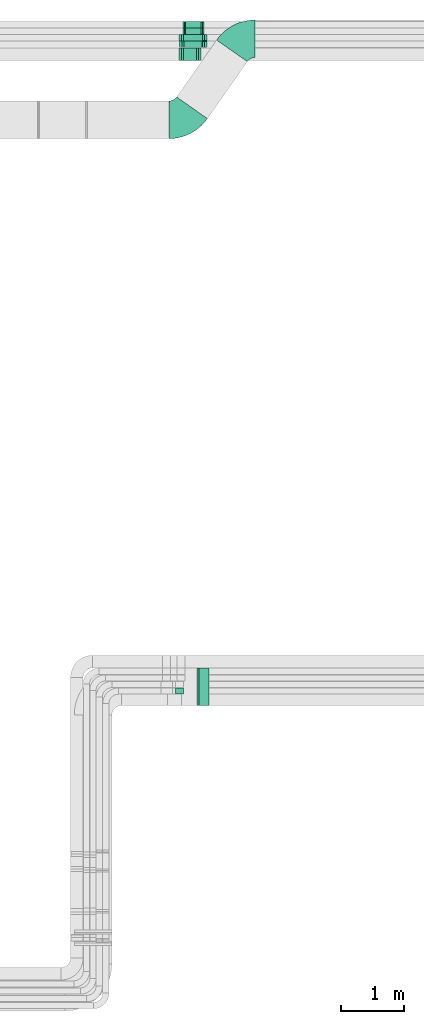
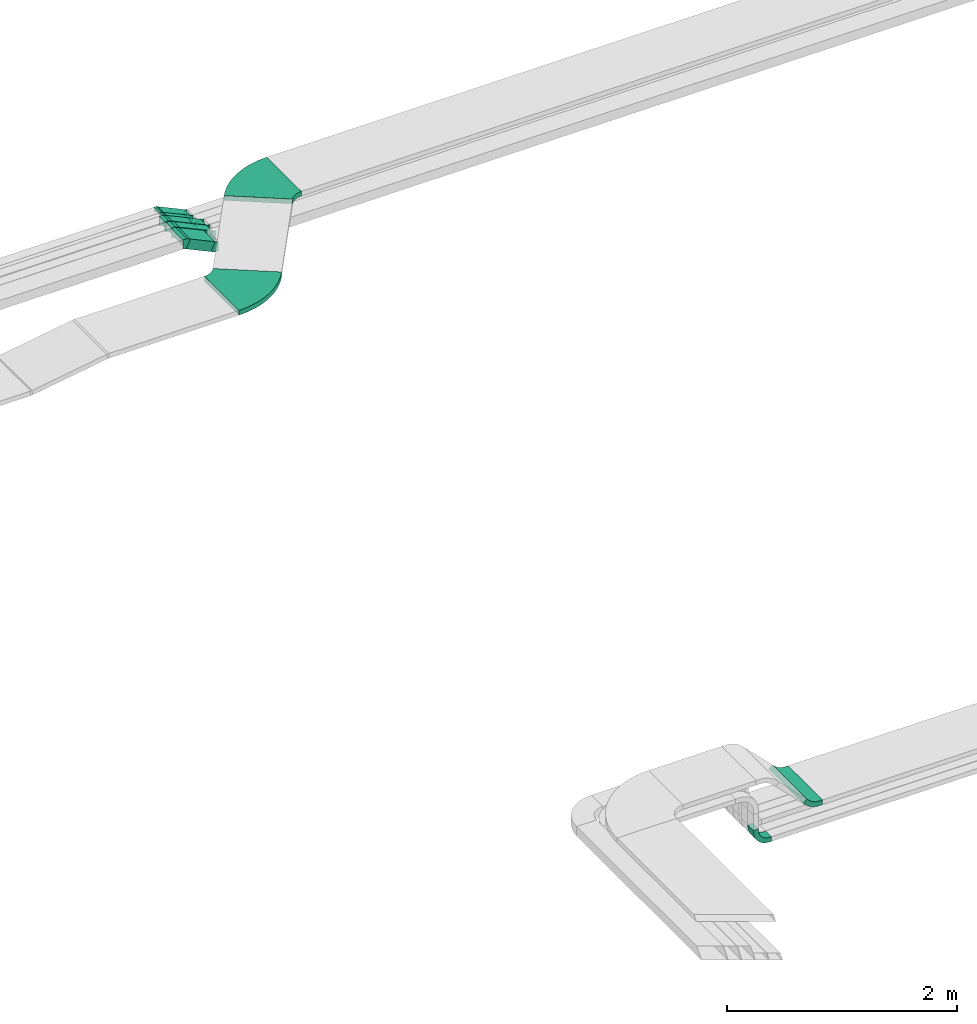
# One storey, part 29 of 38: 14 flow fittings, 5 flow segments.
"""IFC2X3 building model written with IfcOpenShell, lengths in millimetres."""

from ifc_helpers import new_model, entity, si_unit, converted_unit, derived_unit, direction, frame, frame_2d, origin, origin_2d_with_axis, place, context, subcontext, project, spatial, polyline, circle_curve, parameter, trimmed, segment, composite_curve, rectangle, outline, extrude, faceted_brep, source, transform, mapped, material, type_object, type_shapes, element, save


model = new_model("IFC2X3")

# Units and contexts
model_context = context("Model", 3, precision=0.01, world=origin(), true_north=direction((6.12303176911189e-17, 1.0)))
body_context = subcontext(model_context, "Body", "Model", "MODEL_VIEW")
ifc_project = project(units=[si_unit("LENGTHUNIT", "METRE", prefix="MILLI"), si_unit("AREAUNIT", "SQUARE_METRE"), si_unit("VOLUMEUNIT", "CUBIC_METRE"), converted_unit("PLANEANGLEUNIT", "DEGREE", entity("IfcRatioMeasure", 0.0174532925199433), si_unit("PLANEANGLEUNIT", "RADIAN"), dimensions=[0, 0, 0, 0, 0, 0, 0]), si_unit("MASSUNIT", "GRAM", prefix="KILO"), derived_unit("MASSDENSITYUNIT", [(si_unit("MASSUNIT", "GRAM", prefix="KILO"), 1), (si_unit("LENGTHUNIT", "METRE"), -3)]), derived_unit("MOMENTOFINERTIAUNIT", [(si_unit("LENGTHUNIT", "METRE"), 4)]), si_unit("TIMEUNIT", "SECOND"), si_unit("FREQUENCYUNIT", "HERTZ"), si_unit("THERMODYNAMICTEMPERATUREUNIT", "DEGREE_CELSIUS"), derived_unit("THERMALTRANSMITTANCEUNIT", [(si_unit("MASSUNIT", "GRAM", prefix="KILO"), 1), (si_unit("THERMODYNAMICTEMPERATUREUNIT", "KELVIN"), -1), (si_unit("TIMEUNIT", "SECOND"), -3)]), derived_unit("VOLUMETRICFLOWRATEUNIT", [(si_unit("LENGTHUNIT", "METRE"), 3), (si_unit("TIMEUNIT", "SECOND"), -1)]), derived_unit("MASSFLOWRATEUNIT", [(si_unit("MASSUNIT", "GRAM", prefix="KILO"), 1), (si_unit("TIMEUNIT", "SECOND"), -1)]), derived_unit("ROTATIONALFREQUENCYUNIT", [(si_unit("TIMEUNIT", "SECOND"), -1)]), si_unit("ELECTRICCURRENTUNIT", "AMPERE"), si_unit("ELECTRICVOLTAGEUNIT", "VOLT"), si_unit("POWERUNIT", "WATT"), si_unit("FORCEUNIT", "NEWTON", prefix="KILO"), si_unit("ILLUMINANCEUNIT", "LUX"), si_unit("LUMINOUSFLUXUNIT", "LUMEN"), si_unit("LUMINOUSINTENSITYUNIT", "CANDELA"), derived_unit("USERDEFINED", [(si_unit("MASSUNIT", "GRAM", prefix="KILO"), -1), (si_unit("LENGTHUNIT", "METRE"), -2), (si_unit("TIMEUNIT", "SECOND"), 3), (si_unit("LUMINOUSFLUXUNIT", "LUMEN"), 1)]), derived_unit("LINEARVELOCITYUNIT", [(si_unit("LENGTHUNIT", "METRE"), 1), (si_unit("TIMEUNIT", "SECOND"), -1)]), si_unit("PRESSUREUNIT", "PASCAL"), derived_unit("USERDEFINED", [(si_unit("LENGTHUNIT", "METRE"), -2), (si_unit("MASSUNIT", "GRAM", prefix="KILO"), 1), (si_unit("TIMEUNIT", "SECOND"), -2)]), derived_unit("LINEARFORCEUNIT", [(si_unit("MASSUNIT", "GRAM", prefix="KILO"), 1), (si_unit("LENGTHUNIT", "METRE"), 1), (si_unit("TIMEUNIT", "SECOND"), -2), (si_unit("LENGTHUNIT", "METRE"), -1)]), derived_unit("PLANARFORCEUNIT", [(si_unit("MASSUNIT", "GRAM", prefix="KILO"), 1), (si_unit("LENGTHUNIT", "METRE"), 1), (si_unit("TIMEUNIT", "SECOND"), -2), (si_unit("LENGTHUNIT", "METRE"), -2)])], contexts=[model_context])

# Site, building, storey
site_placement = place(None, frame((0.0, -0.00077364408347762, 0.0)))
site = spatial("IfcSite", under=ifc_project, at=site_placement, CompositionType="ELEMENT")
building_placement = place(site_placement, origin())
building = spatial("IfcBuilding", under=site, at=building_placement, CompositionType="ELEMENT")
storey_placement = place(building_placement, frame((0.0, 0.0, 4200.0)))
storey = spatial("IfcBuildingStorey", under=building, at=storey_placement, CompositionType="ELEMENT", Elevation=4200.0)

# Flow segments
cable_carrier_segment_type = type_object("IfcCableCarrierSegmentType", PredefinedType="CABLETRAYSEGMENT")
flow_segment_1_placement = place(storey_placement, frame((40513.1361483519, 15519.4933785571, 2563.34167025878)))
element("IfcFlowSegment", 1, at=flow_segment_1_placement, inside=storey, type_object=cable_carrier_segment_type, context=body_context, shape_type="SweptSolid", body=[
    extrude(rectangle(XDim=100.000000000005, YDim=200.000000000002, at=origin_2d_with_axis()), frame((21.1309130870737, 100.0, 161.413842012185), z_axis=(0.906307787036662, 0.0, -0.422618261740674), x_axis=(0.422618261740674, 0.0, 0.906307787036662)), (0.0, 0.0, 1.0), 274.712342486454),
])
flow_segment_2_placement = place(storey_placement, frame((40522.1363117919, 15728.4164270114, 2520.50914051742)))
element("IfcFlowSegment", 2, at=flow_segment_2_placement, inside=storey, type_object=cable_carrier_segment_type, context=body_context, shape_type="SweptSolid", body=[
    extrude(rectangle(XDim=99.9999999999933, YDim=99.9999999999989, at=frame_2d((0.0, -2.16715534406831e-12), x_axis=(1.0, 0.0))), frame((21.130913087039, 50.0, 200.049526616851), z_axis=(0.90630778703668, 0.0, -0.422618261740636), x_axis=(0.422618261740636, 0.0, 0.90630778703668)), (0.0, 0.0, 1.0), 366.132160564234),
])
flow_segment_3_placement = place(storey_placement, frame((40513.1361483521, 15833.4164270114, 2520.07316217137)))
element("IfcFlowSegment", 3, at=flow_segment_3_placement, inside=storey, type_object=cable_carrier_segment_type, context=body_context, shape_type="SweptSolid", body=[
    extrude(rectangle(XDim=99.9999999999969, YDim=99.9999999999989, at=frame_2d((-9.84101689027739e-13, 0.0), x_axis=(1.0, 0.0))), frame((21.130913087039, 50.0, 204.682350099538), z_axis=(0.906307787036647, 0.0, -0.422618261740707), x_axis=(0.422618261740707, 0.0, 0.906307787036647)), (0.0, 0.0, 1.0), 377.094354823424),
])
flow_segment_4_placement = place(storey_placement, frame((40567.2680979534, 15938.4164270114, 2556.30846834576)))
element("IfcFlowSegment", 4, at=flow_segment_4_placement, inside=storey, type_object=cable_carrier_segment_type, context=body_context, shape_type="SweptSolid", body=[
    extrude(rectangle(XDim=50.0000000000057, YDim=99.9999999999989, at=origin_2d_with_axis()), frame((10.5654565435195, 50.0, 148.13165457331), z_axis=(0.906307787036635, 0.0, -0.422618261740732), x_axis=(0.422618261740732, 0.0, 0.906307787036635)), (0.0, 0.0, 1.0), 296.896682553644),
])
flow_segment_5_placement = place(storey_placement, frame((40567.2680979534, 16039.1762792239, 2556.31475428654)))
element("IfcFlowSegment", 5, at=flow_segment_5_placement, inside=storey, type_object=cable_carrier_segment_type, context=body_context, shape_type="SweptSolid", body=[
    extrude(rectangle(XDim=50.0000000000047, YDim=99.9999999999989, at=origin_2d_with_axis()), frame((10.5654565435195, 50.0, 148.125368632542), z_axis=(0.906307787036631, 0.0, -0.422618261740741), x_axis=(0.422618261740741, 0.0, 0.906307787036631)), (0.0, 0.0, 1.0), 296.881808750623),
])

# Flow fittings
ifc_material = material()
cable_carrier_fitting_type_1 = type_object("IfcCableCarrierFittingType", Name="470_DKC_S5_Variable Angle Elbow 0-45:-", PredefinedType="NOTDEFINED", material=ifc_material)
shared_shape_1 = source(origin(), body_context, "Body", "SweptSolid", [
    extrude(outline(composite_curve([segment(polyline([(-185.202604074125, -396.150089832081), (-184.202604074124, -396.150089832081)]), True, "CONTINUOUS"), segment(trimmed(circle_curve(frame_2d((-184.202604074099, 353.849910167919), x_axis=(0.0, -1.0)), 750.0), [parameter(0.0)], [parameter(55.0)], True, "PARAMETER"), True, "CONTINUOUS"), segment(polyline([(430.16142914263, -76.3324170953858), (430.73500557898, -75.5132650510994)]), True, "CONTINUOUS"), segment(polyline([(430.735005578979, -75.5132650510994), (-60.7562209944005, 268.632596759549)]), True, "CONTINUOUS"), segment(polyline([(-60.7562209944005, 268.632596759549), (-61.3297974307534, 267.813444715258)]), True, "CONTINUOUS"), segment(trimmed(circle_curve(frame_2d((-184.202604074099, 353.849910167919), x_axis=(0.0, -1.0)), 150.0), [parameter(0.0)], [parameter(55.0)], True, "PARAMETER"), False, "CONTINUOUS"), segment(polyline([(-184.202604074103, 203.849910167919), (-185.202604074105, 203.849910167919)]), True, "CONTINUOUS"), segment(polyline([(-185.202604074105, 203.849910167919), (-185.202604074125, -396.150089832081)]), True, "CONTINUOUS")], self_intersect=False)), frame((-50.0525686741649, 96.1500898320789, -25.0)), (0.0, 0.0, 1.0), 50.0000000000068),
])
type_shapes(cable_carrier_fitting_type_1, [shared_shape_1])
flow_fitting_1_placement = place(storey_placement, frame((41463.5869819385, 15866.1524230659, 2823.17400237658), z_axis=(0.0, 0.0, 1.0), x_axis=(-1.0, 0.0, 0.0)))
element("IfcFlowFitting", 6, at=flow_fitting_1_placement, inside=storey, type_object=cable_carrier_fitting_type_1, material=ifc_material, Name="470_DKC_S5_Variable Angle Elbow 0-45:-", ObjectType="470_DKC_S5_Variable Angle Elbow 0-45:-", context=body_context, shape_type="MappedRepresentation", body=[
    mapped(shared_shape_1, transform((0.0, 0.0, 0.0), scale=1.0)),
])
flow_fitting_2_placement = place(storey_placement, frame((40557.3049515864, 14571.8475478723, 2823.17400237658)))
element("IfcFlowFitting", 7, at=flow_fitting_2_placement, inside=storey, type_object=cable_carrier_fitting_type_1, material=ifc_material, Name="470_DKC_S5_Variable Angle Elbow 0-45:-", ObjectType="470_DKC_S5_Variable Angle Elbow 0-45:-", context=body_context, shape_type="MappedRepresentation", body=[
    mapped(shared_shape_1, transform((0.0, 0.0, 0.0), scale=1.0)),
])
cable_carrier_fitting_type_2 = type_object("IfcCableCarrierFittingType", Name="470_DKC_S5_CS 90 internal vertical angle:-", PredefinedType="NOTDEFINED", material=ifc_material)
shared_shape_2 = source(origin(), body_context, "Body", "SweptSolid", [
    extrude(outline(composite_curve([segment(polyline([(-81.2499999999995, -98.7499999999996), (-66.2499999999993, -98.7499999999996)]), True, "CONTINUOUS"), segment(trimmed(circle_curve(frame_2d((-66.2499999999995, 66.2499999999994), x_axis=(0.0, -1.0)), 164.999999999999), [parameter(0.0)], [parameter(90.0)], True, "PARAMETER"), True, "CONTINUOUS"), segment(polyline([(98.7499999999995, 66.2499999999994), (98.7499999999995, 81.2499999999993)]), True, "CONTINUOUS"), segment(polyline([(98.7499999999995, 81.2499999999993), (48.7499999999992, 81.2499999999994)]), True, "CONTINUOUS"), segment(polyline([(48.7499999999992, 81.2499999999994), (48.7499999999992, 66.2499999999994)]), True, "CONTINUOUS"), segment(trimmed(circle_curve(frame_2d((-66.2499999999995, 66.2499999999994), x_axis=(0.0, -1.0)), 114.999999999999), [parameter(0.0)], [parameter(90.0)], True, "PARAMETER"), False, "CONTINUOUS"), segment(polyline([(-66.2499999999993, -48.7499999999994), (-81.2499999999995, -48.7499999999994)]), True, "CONTINUOUS"), segment(polyline([(-81.2499999999995, -48.7499999999994), (-81.2499999999995, -98.7499999999996)]), True, "CONTINUOUS")], self_intersect=False)), frame((-73.7499999999915, 73.7499999999922, -50.0)), (0.0, 0.0, 1.0), 99.9999999999999),
])
type_shapes(cable_carrier_fitting_type_2, [shared_shape_2])
flow_fitting_3_placement = place(storey_placement, frame((40401.1830273063, 5450.19378076426, 2525.0), z_axis=(0.0, -1.0, 0.0), x_axis=(0.0, 0.0, -1.0)))
element("IfcFlowFitting", 8, at=flow_fitting_3_placement, inside=storey, type_object=cable_carrier_fitting_type_2, material=ifc_material, Name="470_DKC_S5_CS 90 internal vertical angle:-", ObjectType="470_DKC_S5_CS 90 internal vertical angle:-", context=body_context, shape_type="MappedRepresentation", body=[
    mapped(shared_shape_2, transform((0.0, 0.0, 0.0), scale=1.0)),
])
cable_carrier_fitting_type_3 = type_object("IfcCableCarrierFittingType", Name="470_DKC_S5_CS 90 internal vertical angle:-", PredefinedType="NOTDEFINED", material=ifc_material)
shared_shape_3 = source(origin(), body_context, "Body", "SweptSolid", [
    extrude(outline(composite_curve([segment(polyline([(-90.9593257258091, -56.1764068711927), (-59.5736828631813, -56.1764068711927)]), True, "CONTINUOUS"), segment(trimmed(circle_curve(frame_2d((-59.5736828631814, 143.823593128806), x_axis=(0.0, -1.0)), 199.999999999999), [parameter(0.0)], [parameter(45.0)], True, "PARAMETER"), True, "CONTINUOUS"), segment(polyline([(81.8476733741271, 2.40223689149736), (104.04067427419, 24.5952377915604)]), True, "CONTINUOUS"), segment(polyline([(104.04067427419, 24.5952377915604), (68.6853352148627, 59.950576850888)]), True, "CONTINUOUS"), segment(polyline([(68.6853352148627, 59.950576850888), (46.4923343147995, 37.7575759508249)]), True, "CONTINUOUS"), segment(trimmed(circle_curve(frame_2d((-59.5736828631814, 143.823593128806), x_axis=(0.0, -1.0)), 149.999999999999), [parameter(0.0)], [parameter(45.0)], True, "PARAMETER"), False, "CONTINUOUS"), segment(polyline([(-59.5736828631812, -6.17640687119247), (-90.959325725809, -6.17640687119245)]), True, "CONTINUOUS"), segment(polyline([(-90.959325725809, -6.17640687119245), (-90.9593257258091, -56.1764068711927)]), True, "CONTINUOUS")], self_intersect=False)), frame((-12.9136905521013, 31.1764068711858, -300.0)), (0.0, 0.0, 1.0), 600.0),
])
type_shapes(cable_carrier_fitting_type_3, [shared_shape_3])
flow_fitting_4_placement = place(storey_placement, frame((40862.1040639796, 5516.65700227204, 2884.50000000003), z_axis=(0.0, -1.0, 0.0), x_axis=(0.707106781186511, 0.0, -0.707106781186584)))
element("IfcFlowFitting", 9, at=flow_fitting_4_placement, inside=storey, type_object=cable_carrier_fitting_type_3, material=ifc_material, Name="470_DKC_S5_CS 90 internal vertical angle:-", ObjectType="470_DKC_S5_CS 90 internal vertical angle:-", context=body_context, shape_type="MappedRepresentation", body=[
    mapped(shared_shape_3, transform((0.0, 0.0, 0.0), scale=1.0)),
])
cable_carrier_fitting_type_4 = type_object("IfcCableCarrierFittingType", PredefinedType="NOTDEFINED", material=ifc_material)
shared_shape_4 = source(origin(), body_context, "Body", "Brep", [
    faceted_brep([(-28.277939577516, -50.0, 100.0), (-28.2779395775156, 50.0, 100.0), (-28.2779395775156, 50.0, 97.4600000101635), (-28.2779395775159, -47.4600000101599, 97.4600000101635), (-28.2779395775159, -47.4600000101599, -97.4600000101564), (-28.2779395775156, 50.0, -97.4600000101564), (-28.2779395775156, 50.0, -100.0), (-28.277939577516, -50.0, -100.0), (46.7594299274949, -33.3646156819681, 100.0), (46.7594299274949, -33.3646156819681, -100.0), (4.49760375341258, 57.2661630216911, -100.0), (4.49760375341256, 57.2661630216911, -97.4600000101564), (45.685979546967, -31.0625939121033, -97.4600000101565), (45.685979546967, -31.0625939121033, 97.4600000101635), (4.49760375341258, 57.2661630216911, 97.4600000101635), (4.49760375341257, 57.2661630216911, 100.0), (11.0847331321509, -50.0, 100.0), (-11.0847331321501, 50.0, 100.0), (-11.0847331321501, 50.0, 97.4600000101635), (10.52162869129, -47.46000001016, 97.4600000101635), (10.52162869129, -47.46000001016, -97.4600000101564), (-11.0847331321501, 50.0, -97.4600000101564), (-11.0847331321501, 50.0, -100.0), (11.0847331321508, -50.0, -100.0)], [[[0, 1, 2, 3, 4, 5, 6, 7]], [[8, 9, 10, 11, 12, 13, 14, 15]], [[1, 0, 16, 8, 15, 17]], [[2, 1, 17, 18]], [[3, 2, 18, 14, 13, 19]], [[4, 3, 19, 20]], [[5, 4, 20, 12, 11, 21]], [[6, 5, 21, 22]], [[7, 6, 22, 10, 9, 23]], [[0, 7, 23, 16]], [[18, 17, 15, 14]], [[20, 19, 13, 12]], [[22, 21, 11, 10]], [[16, 23, 9, 8]]]),
])
type_shapes(cable_carrier_fitting_type_4, [shared_shape_4])
for number, where, z_axis, x_axis in (
    (10, (40808.86951347, 15619.4933785572, 2596.70628594077), (0.0, 1.0, 0.0), (-1.0, 0.0, 0.0)),
    (11, (40508.6385445985, 15619.4933785571, 2736.70628594083), (0.0, -1.0, 0.0), (-0.906307787036659, 0.0, 0.42261826174068)),
):
    element("IfcFlowFitting", number, at=place(storey_placement, frame(where, z_axis=z_axis, x_axis=x_axis)), inside=storey, type_object=cable_carrier_fitting_type_4, material=ifc_material, context=body_context, shape_type="MappedRepresentation", body=[
        mapped(shared_shape_4, transform((0.0, 0.0, 0.0), scale=1.0)),
    ])
cable_carrier_fitting_type_5 = type_object("IfcCableCarrierFittingType", PredefinedType="NOTDEFINED", material=ifc_material)
shared_shape_5 = source(origin(), body_context, "Body", "Brep", [
    faceted_brep([(-28.277939577516, -50.0, 50.0), (-28.2779395775156, 50.0, 50.0), (-28.2779395775156, 50.0, 47.4600000101635), (-28.2779395775159, -47.4600000101599, 47.4600000101635), (-28.2779395775159, -47.4600000101599, -47.4600000101565), (-28.2779395775156, 50.0, -47.4600000101565), (-28.2779395775156, 50.0, -50.0), (-28.277939577516, -50.0, -50.0), (46.7594299274949, -33.3646156819681, 50.0), (46.7594299274949, -33.3646156819681, -50.0), (4.49760375341258, 57.2661630216911, -50.0), (4.49760375341256, 57.2661630216911, -47.4600000101565), (45.685979546967, -31.0625939121033, -47.4600000101565), (45.685979546967, -31.0625939121033, 47.4600000101635), (4.49760375341258, 57.2661630216911, 47.4600000101635), (4.49760375341257, 57.2661630216911, 50.0), (11.0847331321509, -50.0, 50.0), (-11.0847331321501, 50.0, 50.0), (-11.0847331321501, 50.0, 47.4600000101635), (10.52162869129, -47.46000001016, 47.4600000101635), (10.52162869129, -47.46000001016, -47.4600000101565), (-11.0847331321501, 50.0, -47.4600000101565), (-11.0847331321501, 50.0, -50.0), (11.0847331321508, -50.0, -50.0)], [[[0, 1, 2, 3, 4, 5, 6, 7]], [[8, 9, 10, 11, 12, 13, 14, 15]], [[1, 0, 16, 8, 15, 17]], [[2, 1, 17, 18]], [[3, 2, 18, 14, 13, 19]], [[4, 3, 19, 20]], [[5, 4, 20, 12, 11, 21]], [[6, 5, 21, 22]], [[7, 6, 22, 10, 9, 23]], [[0, 7, 23, 16]], [[18, 17, 15, 14]], [[20, 19, 13, 12]], [[22, 21, 11, 10]], [[16, 23, 9, 8]]]),
])
type_shapes(cable_carrier_fitting_type_5, [shared_shape_5])
for number, where, z_axis, x_axis in (
    (12, (40900.7241699233, 15778.4164270115, 2553.87375619939), (0.0, -1.0, 0.0), (0.906307787036655, 0.0, -0.422618261740689)),
    (13, (40517.6387080385, 15778.4164270115, 2732.50944080413), (0.0, -1.0, 0.0), (-0.906307787036656, 0.0, 0.422618261740687)),
    (14, (40901.6591285036, 15883.4164270115, 2553.43777785335), (0.0, -1.0, 0.0), (0.906307787036657, 0.0, -0.422618261740685)),
    (15, (40508.6385445987, 15883.4164270114, 2736.70628594076), (0.0, -1.0, 0.0), (-0.906307787036657, 0.0, 0.422618261740684)),
):
    element("IfcFlowFitting", number, at=place(storey_placement, frame(where, z_axis=z_axis, x_axis=x_axis)), inside=storey, type_object=cable_carrier_fitting_type_5, material=ifc_material, context=body_context, shape_type="MappedRepresentation", body=[
        mapped(shared_shape_5, transform((0.0, 0.0, 0.0), scale=1.0)),
    ])
cable_carrier_fitting_type_6 = type_object("IfcCableCarrierFittingType", PredefinedType="NOTDEFINED", material=ifc_material)
shared_shape_6 = source(origin(), body_context, "Body", "Brep", [
    faceted_brep([(-17.1932064453609, -25.0, 50.0), (-17.1932064453608, 25.0, 50.0), (-17.1932064453608, 25.0, 47.4600000101635), (-17.1932064453609, -22.4600000101599, 47.4600000101635), (-17.1932064453609, -22.4600000101599, -47.4600000101565), (-17.1932064453608, 25.0, -47.4600000101565), (-17.1932064453608, 25.0, -50.0), (-17.1932064453609, -25.0, -50.0), (26.1477934290797, -15.3915316542256, 50.0), (26.1477934290797, -15.3915316542256, -50.0), (5.0168803420386, 29.9238576976041, -50.0), (5.0168803420386, 29.9238576976041, -47.4600000101565), (25.0743430485518, -13.0895098843607, -47.4600000101565), (25.0743430485518, -13.0895098843607, 47.4600000101635), (5.0168803420386, 29.9238576976041, 47.4600000101635), (5.01688034203859, 29.9238576976041, 50.0), (5.5423665660757, -25.0, 50.0), (-5.5423665660749, 25.0, 50.0), (-5.5423665660749, 25.0, 47.4600000101635), (4.97926212521477, -22.46000001016, 47.4600000101635), (4.97926212521477, -22.46000001016, -47.4600000101565), (-5.5423665660749, 25.0, -47.4600000101565), (-5.5423665660749, 25.0, -50.0), (5.54236656607559, -25.0, -50.0)], [[[0, 1, 2, 3, 4, 5, 6, 7]], [[8, 9, 10, 11, 12, 13, 14, 15]], [[1, 0, 16, 8, 15, 17]], [[2, 1, 17, 18]], [[3, 2, 18, 14, 13, 19]], [[4, 3, 19, 20]], [[5, 4, 20, 12, 11, 21]], [[6, 5, 21, 22]], [[7, 6, 22, 10, 9, 23]], [[0, 7, 23, 16]], [[18, 17, 15, 14]], [[20, 19, 13, 12]], [[22, 21, 11, 10]], [[16, 23, 9, 8]]]),
])
type_shapes(cable_carrier_fitting_type_6, [shared_shape_6])
for number, where, z_axis, x_axis in (
    (16, (40862.4821864827, 16089.1762792239, 2571.70628594078), (0.0, -1.0, 0.0), (0.906307787036659, 0.0, -0.42261826174068)),
    (17, (40562.2512176114, 15988.4164270114, 2711.70628594076), (0.0, -1.0, 0.0), (-0.906307787036662, 0.0, 0.422618261740673)),
    (18, (40562.2512176114, 16089.1762792239, 2711.70628594076), (0.0, -1.0, 0.0), (-0.906307787036652, 0.0, 0.422618261740696)),
    (19, (40862.4956667262, 15988.4164270114, 2571.69999999999), (0.0, -1.0, 0.0), (0.906307787036664, 0.0, -0.422618261740669)),
):
    element("IfcFlowFitting", number, at=place(storey_placement, frame(where, z_axis=z_axis, x_axis=x_axis)), inside=storey, type_object=cable_carrier_fitting_type_6, material=ifc_material, context=body_context, shape_type="MappedRepresentation", body=[
        mapped(shared_shape_6, transform((0.0, 0.0, 0.0), scale=1.0)),
    ])

save(model, "model.ifc")
